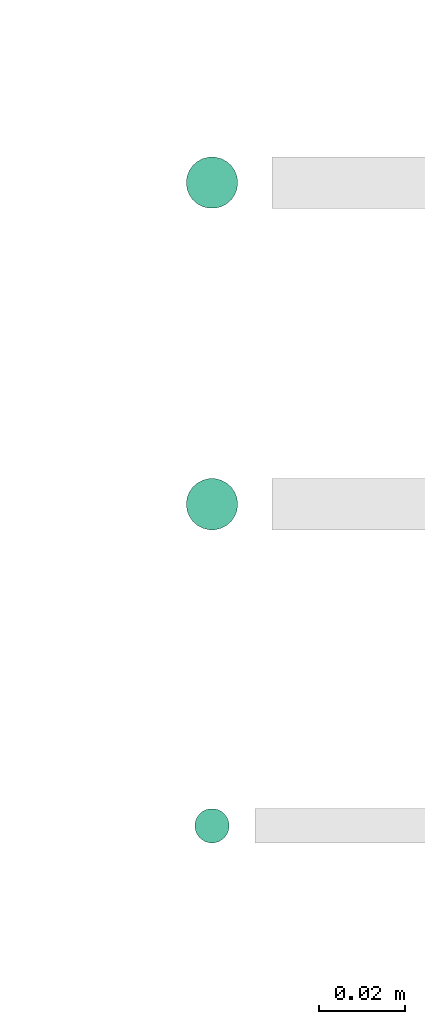
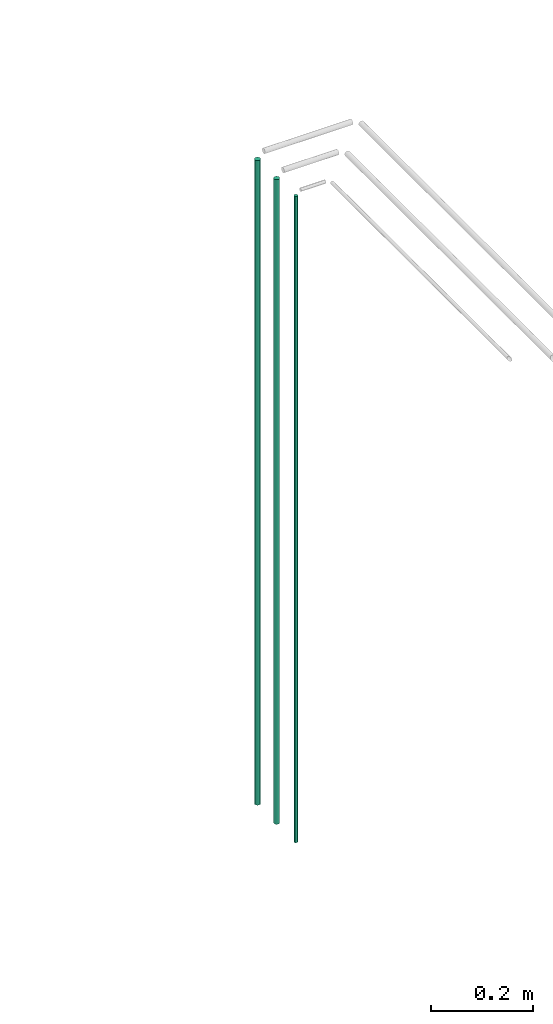
# One storey, part 22 of 331: 3 flow segments.
"""IFC2X3 building model written with IfcOpenShell, lengths in millimetres."""

from ifc_helpers import new_model, entity, si_unit, converted_unit, derived_unit, direction, frame, origin, origin_2d_with_axis, place, context, subcontext, project, spatial, circle, extrude, type_object, element, save


model = new_model("IFC2X3")

# Units and contexts
model_context = context("Model", 3, precision=0.01, world=origin(), true_north=direction((6.12303176911189e-17, 1.0)))
body_context = subcontext(model_context, "Body", "Model", "MODEL_VIEW")
ifc_project = project(units=[si_unit("LENGTHUNIT", "METRE", prefix="MILLI"), si_unit("AREAUNIT", "SQUARE_METRE"), si_unit("VOLUMEUNIT", "CUBIC_METRE"), converted_unit("PLANEANGLEUNIT", "DEGREE", entity("IfcRatioMeasure", 0.0174532925199433), si_unit("PLANEANGLEUNIT", "RADIAN"), dimensions=[0, 0, 0, 0, 0, 0, 0]), si_unit("MASSUNIT", "GRAM", prefix="KILO"), derived_unit("MASSDENSITYUNIT", [(si_unit("MASSUNIT", "GRAM", prefix="KILO"), 1), (si_unit("LENGTHUNIT", "METRE"), -3)]), derived_unit("MOMENTOFINERTIAUNIT", [(si_unit("LENGTHUNIT", "METRE"), 4)]), si_unit("TIMEUNIT", "SECOND"), si_unit("FREQUENCYUNIT", "HERTZ"), si_unit("THERMODYNAMICTEMPERATUREUNIT", "DEGREE_CELSIUS"), derived_unit("THERMALTRANSMITTANCEUNIT", [(si_unit("MASSUNIT", "GRAM", prefix="KILO"), 1), (si_unit("THERMODYNAMICTEMPERATUREUNIT", "KELVIN"), -1), (si_unit("TIMEUNIT", "SECOND"), -3)]), derived_unit("VOLUMETRICFLOWRATEUNIT", [(si_unit("LENGTHUNIT", "METRE"), 3), (si_unit("TIMEUNIT", "SECOND"), -1)]), derived_unit("MASSFLOWRATEUNIT", [(si_unit("MASSUNIT", "GRAM", prefix="KILO"), 1), (si_unit("TIMEUNIT", "SECOND"), -1)]), derived_unit("ROTATIONALFREQUENCYUNIT", [(si_unit("TIMEUNIT", "SECOND"), -1)]), si_unit("ELECTRICCURRENTUNIT", "AMPERE"), si_unit("ELECTRICVOLTAGEUNIT", "VOLT"), si_unit("POWERUNIT", "WATT"), si_unit("FORCEUNIT", "NEWTON", prefix="KILO"), si_unit("ILLUMINANCEUNIT", "LUX"), si_unit("LUMINOUSFLUXUNIT", "LUMEN"), si_unit("LUMINOUSINTENSITYUNIT", "CANDELA"), derived_unit("USERDEFINED", [(si_unit("MASSUNIT", "GRAM", prefix="KILO"), -1), (si_unit("LENGTHUNIT", "METRE"), -2), (si_unit("TIMEUNIT", "SECOND"), 3), (si_unit("LUMINOUSFLUXUNIT", "LUMEN"), 1)]), derived_unit("LINEARVELOCITYUNIT", [(si_unit("LENGTHUNIT", "METRE"), 1), (si_unit("TIMEUNIT", "SECOND"), -1)]), si_unit("PRESSUREUNIT", "PASCAL"), derived_unit("USERDEFINED", [(si_unit("LENGTHUNIT", "METRE"), -2), (si_unit("MASSUNIT", "GRAM", prefix="KILO"), 1), (si_unit("TIMEUNIT", "SECOND"), -2)]), derived_unit("LINEARFORCEUNIT", [(si_unit("MASSUNIT", "GRAM", prefix="KILO"), 1), (si_unit("LENGTHUNIT", "METRE"), 1), (si_unit("TIMEUNIT", "SECOND"), -2), (si_unit("LENGTHUNIT", "METRE"), -1)]), derived_unit("PLANARFORCEUNIT", [(si_unit("MASSUNIT", "GRAM", prefix="KILO"), 1), (si_unit("LENGTHUNIT", "METRE"), 1), (si_unit("TIMEUNIT", "SECOND"), -2), (si_unit("LENGTHUNIT", "METRE"), -2)])], contexts=[model_context])

# Site, building, storey
site_placement = place(None, frame((0.0, -0.00077364408347762, 0.0)))
site = spatial("IfcSite", under=ifc_project, at=site_placement, CompositionType="ELEMENT")
building_placement = place(site_placement, origin())
building = spatial("IfcBuilding", under=site, at=building_placement, CompositionType="ELEMENT")
storey_placement = place(building_placement, origin())
storey = spatial("IfcBuildingStorey", under=building, at=storey_placement, CompositionType="ELEMENT", Elevation=0.0)

# Flow segments
pipe_segment_type = type_object("IfcPipeSegmentType", PredefinedType="NOTDEFINED")
flow_segment_placement = place(storey_placement, frame((21589.9883435624, 18869.4047277643, 5700.0)))
element("IfcFlowSegment", 1, at=flow_segment_placement, inside=storey, type_object=pipe_segment_type, context=body_context, shape_type="SweptSolid", body=[
    extrude(circle(Radius=4.0, at=origin_2d_with_axis()), frame((5.59527223591499, 5.59527223591499, 0.0)), (0.0, 0.0, 1.0), 1540.00000000001),
])
for number, where in (
    (2, (21587.9883435624, 18942.4047277643, 5700.0)),
    (3, (21587.9883435625, 19017.390171611, 5700.0)),
):
    element("IfcFlowSegment", number, at=place(storey_placement, frame(where)), inside=storey, type_object=pipe_segment_type, context=body_context, shape_type="SweptSolid", body=[
        extrude(circle(Radius=6.0, at=origin_2d_with_axis()), frame((7.59527223591454, 7.5952722359167, 0.0)), (0.0, 0.0, 1.0), 1536.0),
    ])

save(model, "model.ifc")
